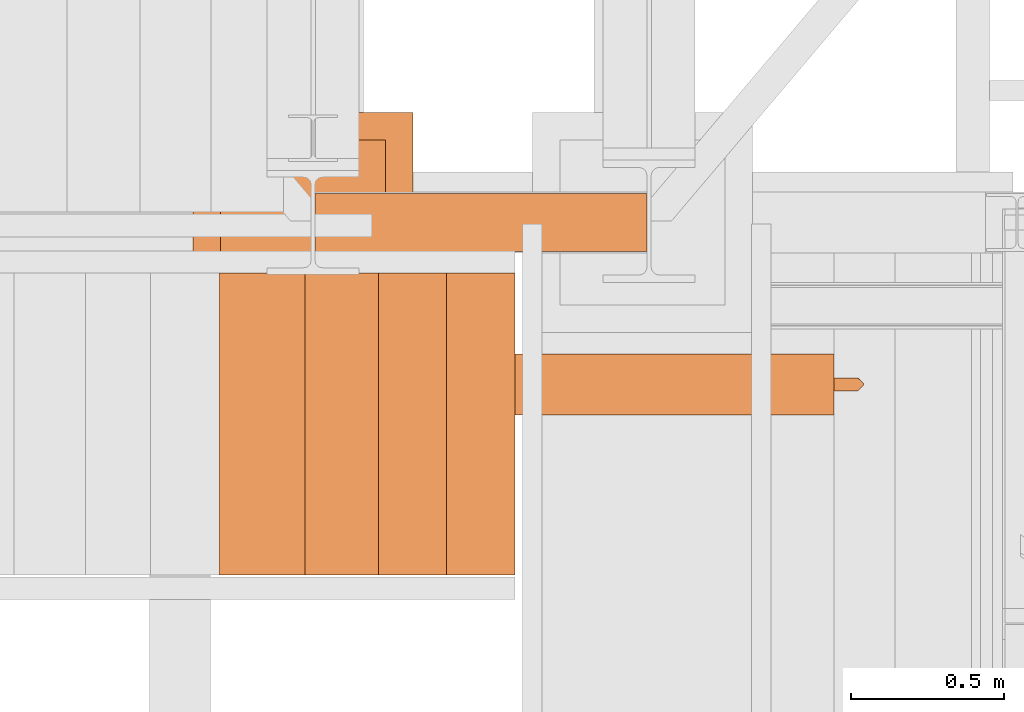
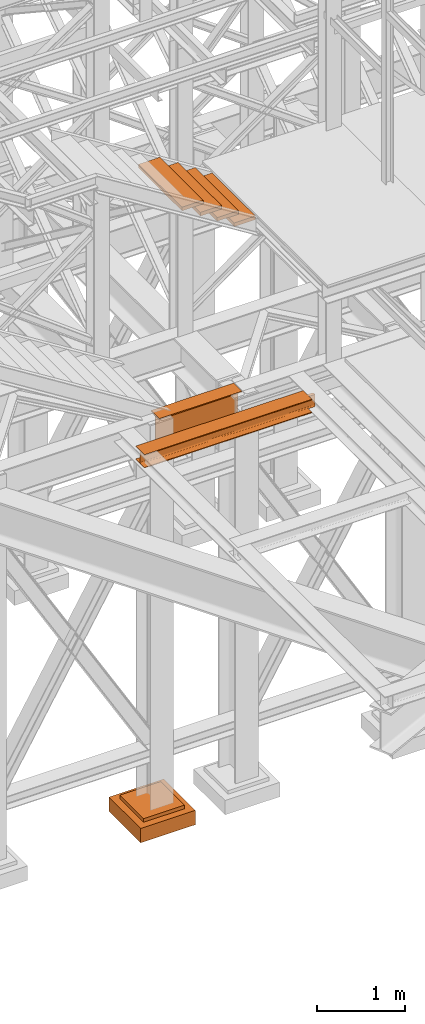
# One storey, part 23 of 208: 7 proxies.
"""IFC2X3 building model written with IfcOpenShell, lengths in millimetres."""

from ifc_helpers import new_model, entity, si_unit, converted_unit, frame, origin, origin_with_axes, place, context, subcontext, project, spatial, faceted_brep, element, save


model = new_model("IFC2X3")

# Units and contexts
model_context = context("Model", 3, precision=1e-05, world=origin())
plan_context = context("Plan", 3, precision=1e-05, world=origin())
body_context = subcontext(model_context, "Body", "Model", "MODEL_VIEW")
ifc_project = project(units=[si_unit("LENGTHUNIT", "METRE", prefix="MILLI"), converted_unit("PLANEANGLEUNIT", "DEGREE", entity("IfcPlaneAngleMeasure", 0.0174532925199433), si_unit("PLANEANGLEUNIT", "RADIAN"), dimensions=[0, 0, 0, 0, 0, 0, 0]), si_unit("AREAUNIT", "SQUARE_METRE"), si_unit("VOLUMEUNIT", "CUBIC_METRE")], contexts=[model_context, plan_context])

# Building, storey
building_placement = place(None, origin())
building = spatial("IfcBuilding", under=ifc_project, at=building_placement, CompositionType="COMPLEX")
storey_placement = place(building_placement, origin_with_axes())
storey = spatial("IfcBuildingStorey", under=building, at=storey_placement, Name="Geschoss", CompositionType="ELEMENT")

# Proxies
proxy_1_placement = place(storey_placement, frame((-1100.745031419179, -17357.574399786, 4834.989987483023), z_axis=(0.0, 0.0, 1.0), x_axis=(1.0, 0.0, 0.0)))
element("IfcBuildingElementProxy", 1, at=proxy_1_placement, inside=storey, context=body_context, shape_type="Brep", body=[
    faceted_brep([(1088.009999895696, 0.00999999999839929, 450.0100178813937), (1088.009999895696, 190.0100125169738, 450.0100178813937), (1088.009999895696, 190.0100125169738, 435.4100240564349), (1088.009999895696, 120.7100073045476, 435.4100091552737), (1088.009999895696, 109.8415622657522, 433.2347078418734), (1088.009999895696, 101.8853126263603, 425.2784563398363), (1088.009999895696, 99.71000619068582, 414.4100113010409), (1088.009999895696, 99.71000619068582, 35.60999167919181), (1088.009999895696, 101.8853126263603, 24.74154664039634), (1088.009999895696, 109.8415622657522, 16.78529513835929), (1088.009999895696, 120.7100073045476, 14.60999382495902), (1088.009999895696, 190.0100125169738, 14.60999382495902), (1088.009999895696, 190.0100125169738, 0.01000000000021828), (1088.009999895696, 0.00999999999839929, 0.01000000000021828), (1088.009999895696, 0.00999999999839929, 14.60999382495902), (1088.009999895696, 69.31000521242458, 14.60999382495902), (1088.009999895696, 80.17845025122006, 16.78529513835929), (1088.009999895696, 88.13469989061196, 24.74154664039634), (1088.009999895696, 90.31000632628638, 35.60999167919181), (1088.009999895696, 90.31000632628638, 414.4100113010409), (1088.009999895696, 88.13469989061196, 425.2784563398363), (1088.009999895696, 80.17845025122006, 433.2347078418734), (1088.009999895696, 69.31000521242458, 435.4100091552737), (1088.009999895696, 0.00999999999839929, 435.4100240564349), (1088.009999895696, 190.0100125169738, 450.0100178813937), (1088.009999895696, 0.00999999999839929, 450.0100178813937), (0.009999999999990905, 0.00999999999839929, 450.0100178813937), (0.009999999999990905, 190.0100125169738, 450.0100178813937), (1088.009999895696, 190.0100125169738, 435.4100240564349), (1088.009999895696, 190.0100125169738, 450.0100178813937), (0.009999999999990905, 190.0100125169738, 450.0100178813937), (0.009999999999990905, 190.0100125169738, 435.4100240564349), (1088.009999895696, 120.7100073045476, 435.4100091552737), (1088.009999895696, 190.0100125169738, 435.4100240564349), (0.009999999999990905, 190.0100125169738, 435.4100240564349), (0.009999999999990905, 120.7100073045476, 435.4100091552737), (1088.009999895696, 109.8415622657522, 433.2347078418734), (1088.009999895696, 120.7100073045476, 435.4100091552737), (0.009999999999990905, 120.7100073045476, 435.4100091552737), (0.009999999999990905, 109.8415622657522, 433.2347078418734), (1088.009999895696, 101.8853126263603, 425.2784563398363), (1088.009999895696, 109.8415622657522, 433.2347078418734), (0.009999999999990905, 109.8415622657522, 433.2347078418734), (0.009999999999990905, 101.8853126263603, 425.2784563398363), (1088.009999895696, 99.71000619068582, 414.4100113010409), (1088.009999895696, 101.8853126263603, 425.2784563398363), (0.009999999999990905, 101.8853126263603, 425.2784563398363), (0.009999999999990905, 99.71000619068582, 414.4100113010409), (1088.009999895696, 99.71000619068582, 35.60999167919181), (1088.009999895696, 99.71000619068582, 414.4100113010409), (0.009999999999990905, 99.71000619068582, 414.4100113010409), (0.009999999999990905, 99.71000619068582, 35.60999167919181), (1088.009999895696, 101.8853126263603, 24.74154664039634), (1088.009999895696, 99.71000619068582, 35.60999167919181), (0.009999999999990905, 99.71000619068582, 35.60999167919181), (0.009999999999990905, 101.8853126263603, 24.74154664039634), (1088.009999895696, 109.8415622657522, 16.78529513835929), (1088.009999895696, 101.8853126263603, 24.74154664039634), (0.009999999999990905, 101.8853126263603, 24.74154664039634), (0.009999999999990905, 109.8415622657522, 16.78529513835929), (1088.009999895696, 120.7100073045476, 14.60999382495902), (1088.009999895696, 109.8415622657522, 16.78529513835929), (0.009999999999990905, 109.8415622657522, 16.78529513835929), (0.009999999999990905, 120.7100073045476, 14.60999382495902), (1088.009999895696, 190.0100125169738, 14.60999382495902), (1088.009999895696, 120.7100073045476, 14.60999382495902), (0.009999999999990905, 120.7100073045476, 14.60999382495902), (0.009999999999990905, 190.0100125169738, 14.60999382495902), (1088.009999895696, 190.0100125169738, 0.01000000000021828), (1088.009999895696, 190.0100125169738, 14.60999382495902), (0.009999999999990905, 190.0100125169738, 14.60999382495902), (0.009999999999990905, 190.0100125169738, 0.01000000000021828), (1088.009999895696, 0.00999999999839929, 0.01000000000021828), (1088.009999895696, 190.0100125169738, 0.01000000000021828), (0.009999999999990905, 190.0100125169738, 0.01000000000021828), (0.009999999999990905, 0.00999999999839929, 0.01000000000021828), (1088.009999895696, 0.00999999999839929, 14.60999382495902), (1088.009999895696, 0.00999999999839929, 0.01000000000021828), (0.009999999999990905, 0.00999999999839929, 0.01000000000021828), (0.009999999999990905, 0.00999999999839929, 14.60999382495902), (1088.009999895696, 69.31000521242458, 14.60999382495902), (1088.009999895696, 0.00999999999839929, 14.60999382495902), (0.009999999999990905, 0.00999999999839929, 14.60999382495902), (0.009999999999990905, 69.31000521242458, 14.60999382495902), (1088.009999895696, 80.17845025122006, 16.78529513835929), (1088.009999895696, 69.31000521242458, 14.60999382495902), (0.009999999999990905, 69.31000521242458, 14.60999382495902), (0.009999999999990905, 80.17845025122006, 16.78529513835929), (1088.009999895696, 88.13469989061196, 24.74154664039634), (1088.009999895696, 80.17845025122006, 16.78529513835929), (0.009999999999990905, 80.17845025122006, 16.78529513835929), (0.009999999999990905, 88.13469989061196, 24.74154664039634), (1088.009999895696, 90.31000632628638, 35.60999167919181), (1088.009999895696, 88.13469989061196, 24.74154664039634), (0.009999999999990905, 88.13469989061196, 24.74154664039634), (0.009999999999990905, 90.31000632628638, 35.60999167919181), (1088.009999895696, 90.31000632628638, 414.4100113010409), (1088.009999895696, 90.31000632628638, 35.60999167919181), (0.009999999999990905, 90.31000632628638, 35.60999167919181), (0.009999999999990905, 90.31000632628638, 414.4100113010409), (1088.009999895696, 88.13469989061196, 425.2784563398363), (1088.009999895696, 90.31000632628638, 414.4100113010409), (0.009999999999990905, 90.31000632628638, 414.4100113010409), (0.009999999999990905, 88.13469989061196, 425.2784563398363), (1088.009999895696, 80.17845025122006, 433.2347078418734), (1088.009999895696, 88.13469989061196, 425.2784563398363), (0.009999999999990905, 88.13469989061196, 425.2784563398363), (0.009999999999990905, 80.17845025122006, 433.2347078418734), (1088.009999895696, 69.31000521242458, 435.4100091552737), (1088.009999895696, 80.17845025122006, 433.2347078418734), (0.009999999999990905, 80.17845025122006, 433.2347078418734), (0.009999999999990905, 69.31000521242458, 435.4100091552737), (1088.009999895696, 0.00999999999839929, 435.4100240564349), (1088.009999895696, 69.31000521242458, 435.4100091552737), (0.009999999999990905, 69.31000521242458, 435.4100091552737), (0.009999999999990905, 0.00999999999839929, 435.4100240564349), (1088.009999895696, 0.00999999999839929, 450.0100178813937), (1088.009999895696, 0.00999999999839929, 435.4100240564349), (0.009999999999990905, 0.00999999999839929, 435.4100240564349), (0.009999999999990905, 0.00999999999839929, 450.0100178813937), (0.009999999999990905, 0.00999999999839929, 450.0100178813937), (0.009999999999990905, 0.00999999999839929, 435.4100240564349), (0.009999999999990905, 69.31000521242458, 435.4100091552737), (0.009999999999990905, 80.17845025122006, 433.2347078418734), (0.009999999999990905, 88.13469989061196, 425.2784563398363), (0.009999999999990905, 90.31000632628638, 414.4100113010409), (0.009999999999990905, 90.31000632628638, 35.60999167919181), (0.009999999999990905, 88.13469989061196, 24.74154664039634), (0.009999999999990905, 80.17845025122006, 16.78529513835929), (0.009999999999990905, 69.31000521242458, 14.60999382495902), (0.009999999999990905, 0.00999999999839929, 14.60999382495902), (0.009999999999990905, 0.00999999999839929, 0.01000000000021828), (0.009999999999990905, 190.0100125169738, 0.01000000000021828), (0.009999999999990905, 190.0100125169738, 14.60999382495902), (0.009999999999990905, 120.7100073045476, 14.60999382495902), (0.009999999999990905, 109.8415622657522, 16.78529513835929), (0.009999999999990905, 101.8853126263603, 24.74154664039634), (0.009999999999990905, 99.71000619068582, 35.60999167919181), (0.009999999999990905, 99.71000619068582, 414.4100113010409), (0.009999999999990905, 101.8853126263603, 425.2784563398363), (0.009999999999990905, 109.8415622657522, 433.2347078418734), (0.009999999999990905, 120.7100073045476, 435.4100091552737), (0.009999999999990905, 190.0100125169738, 435.4100240564349), (0.009999999999990905, 190.0100125169738, 450.0100178813937)], [[[0, 1, 2, 3, 4, 5, 6, 7, 8, 9, 10, 11, 12, 13, 14, 15, 16, 17, 18, 19, 20, 21, 22, 23]], [[24, 25, 26, 27]], [[28, 29, 30, 31]], [[32, 33, 34, 35]], [[36, 37, 38, 39]], [[40, 41, 42, 43]], [[44, 45, 46, 47]], [[48, 49, 50, 51]], [[52, 53, 54, 55]], [[56, 57, 58, 59]], [[60, 61, 62, 63]], [[64, 65, 66, 67]], [[68, 69, 70, 71]], [[72, 73, 74, 75]], [[76, 77, 78, 79]], [[80, 81, 82, 83]], [[84, 85, 86, 87]], [[88, 89, 90, 91]], [[92, 93, 94, 95]], [[96, 97, 98, 99]], [[100, 101, 102, 103]], [[104, 105, 106, 107]], [[108, 109, 110, 111]], [[112, 113, 114, 115]], [[116, 117, 118, 119]], [[120, 121, 122, 123, 124, 125, 126, 127, 128, 129, 130, 131, 132, 133, 134, 135, 136, 137, 138, 139, 140, 141, 142, 143]]], orient=[[False], [False], [False], [False], [False], [False], [False], [False], [False], [False], [False], [False], [False], [False], [False], [False], [False], [False], [False], [False], [False], [False], [False], [False], [False], [False]]),
])
proxy_2_placement = place(storey_placement, frame((-1499.794506223427, -17622.57439531565, -315.0099999999999), z_axis=(0.0, 0.0, 1.0), x_axis=(1.0, 0.0, 0.0)))
element("IfcBuildingElementProxy", 2, at=proxy_2_placement, inside=storey, context=body_context, shape_type="Brep", body=[
    faceted_brep([(630.01, 630.0099999999984, 250.01), (630.01, 90.0099999999984, 250.01), (90.00999999999999, 90.0099999999984, 250.01), (90.00999999999999, 630.0099999999984, 250.01), (630.01, 630.0099999999984, 200.01), (630.01, 90.0099999999984, 200.01), (630.01, 90.0099999999984, 250.01), (630.01, 630.0099999999984, 250.01), (90.00999999999999, 630.0099999999984, 200.01), (630.01, 630.0099999999984, 200.01), (630.01, 630.0099999999984, 250.01), (90.00999999999999, 630.0099999999984, 250.01), (90.00999999999999, 90.0099999999984, 200.01), (90.00999999999999, 630.0099999999984, 200.01), (90.00999999999999, 630.0099999999984, 250.01), (90.00999999999999, 90.0099999999984, 250.01), (630.01, 90.0099999999984, 200.01), (90.00999999999999, 90.0099999999984, 200.01), (90.00999999999999, 90.0099999999984, 250.01), (630.01, 90.0099999999984, 250.01), (720.01, 0.00999999999839929, 0.009999999999990905), (720.01, 720.0099999999984, 0.009999999999990905), (0.009999999999990905, 720.0099999999984, 0.009999999999990905), (0.009999999999990905, 0.00999999999839929, 0.009999999999990905), (720.01, 720.0099999999984, 200.01), (720.01, 0.00999999999839929, 200.01), (0.009999999999990905, 0.00999999999839929, 200.01), (0.009999999999990905, 720.0099999999984, 200.01), (90.00999999999999, 90.0099999999984, 200.01), (630.01, 90.0099999999984, 200.01), (630.01, 630.0099999999984, 200.01), (90.00999999999999, 630.0099999999984, 200.01), (720.01, 720.0099999999984, 0.009999999999990905), (720.01, 0.00999999999839929, 0.009999999999990905), (720.01, 0.00999999999839929, 200.01), (720.01, 720.0099999999984, 200.01), (0.009999999999990905, 720.0099999999984, 0.009999999999990905), (720.01, 720.0099999999984, 0.009999999999990905), (720.01, 720.0099999999984, 200.01), (0.009999999999990905, 720.0099999999984, 200.01), (0.009999999999990905, 0.00999999999839929, 0.009999999999990905), (0.009999999999990905, 720.0099999999984, 0.009999999999990905), (0.009999999999990905, 720.0099999999984, 200.01), (0.009999999999990905, 0.00999999999839929, 200.01), (720.01, 0.00999999999839929, 0.009999999999990905), (0.009999999999990905, 0.00999999999839929, 0.009999999999990905), (0.009999999999990905, 0.00999999999839929, 200.01), (720.01, 0.00999999999839929, 200.01)], [[[0, 1, 2, 3]], [[4, 5, 6, 7]], [[8, 9, 10, 11]], [[12, 13, 14, 15]], [[16, 17, 18, 19]], [[20, 21, 22, 23]], [[24, 25, 26, 27], [28, 29, 30, 31]], [[32, 33, 34, 35]], [[36, 37, 38, 39]], [[40, 41, 42, 43]], [[44, 45, 46, 47]]], orient=[[False], [False], [False], [False], [False], [False], [False, False], [False], [False], [False], [False]]),
])
proxy_3_placement = place(storey_placement, frame((-1605.876075509834, -17892.50386180536, 5094.990005364416), z_axis=(0.0, 0.0, 1.0), x_axis=(1.0, 0.0, 0.0)))
element("IfcBuildingElementProxy", 3, at=proxy_3_placement, inside=storey, context=body_context, shape_type="Brep", body=[
    faceted_brep([(0.01000000000180989, 200.0099999999984, 0.01000000000021828), (2204.141044038497, 200.0099999999984, 0.01000000000021828), (2204.141044038497, 200.0099999999984, 10.01000000000022), (0.01000000000180989, 200.0099999999984, 10.01000000000022), (0.01000000000180989, 200.0099999999984, 10.01000000000022), (2204.141044038497, 200.0099999999984, 10.01000000000022), (2204.141044038497, 121.2599999999984, 10.01000000000022), (0.01000000000180989, 121.2599999999984, 10.01000000000022), (0.01000000000180989, 121.2599999999984, 10.01000000000022), (2204.141044038497, 121.2599999999984, 10.01000000000022), (2282.891044038497, 121.2599999999984, 10.01000000000022), (2288.453331069071, 115.6977129694242, 10.89104403849342), (0.01000000000180989, 115.6977129694242, 10.89104403849342), (0.01000000000180989, 115.6977129694242, 10.89104403849342), (2288.453331069071, 115.6977129694242, 10.89104403849342), (2293.471160749032, 110.6798832894638, 13.44771635773213), (0.01000000000180989, 110.6798832894638, 13.44771635773213), (0.01000000000180989, 110.6798832894638, 13.44771635773213), (2293.471160749032, 110.6798832894638, 13.44771635773213), (2297.453327680767, 106.6977163577321, 17.42988328946558), (0.01000000000180989, 106.6977163577321, 17.42988328946558), (0.01000000000180989, 106.6977163577321, 17.42988328946558), (2297.453327680767, 106.6977163577321, 17.42988328946558), (2300.010000000002, 104.1410440384934, 22.44771296942599), (0.01000000000180989, 104.1410440384934, 22.44771296942599), (0.01000000000180989, 104.1410440384934, 22.44771296942599), (2300.010000000002, 104.1410440384934, 22.44771296942599), (2300.891044038497, 103.2599999999984, 28.01000000000022), (0.01000000000362888, 103.2599999999984, 28.01000000000022), (0.01000000000362888, 103.2599999999984, 28.01000000000022), (2300.891044038497, 103.2599999999984, 28.01000000000022), (2300.891044038497, 103.2599999999984, 162.0100000000002), (0.01000000000180989, 103.2599999999984, 162.0100000000002), (0.01000000000180989, 103.2599999999984, 162.0100000000002), (2300.891044038497, 103.2599999999984, 162.0100000000002), (2300.010000000002, 104.1410440384934, 167.5722870305744), (0.01000000000180989, 104.1410440384934, 167.5722870305744), (0.01000000000180989, 104.1410440384934, 167.5722870305744), (2300.010000000002, 104.1410440384934, 167.5722870305744), (2297.453327680767, 106.6977163577321, 172.5901167105349), (0.009999999999990905, 106.6977163577321, 172.5901167105349), (0.009999999999990905, 106.6977163577321, 172.5901167105349), (2297.453327680767, 106.6977163577321, 172.5901167105349), (2293.471160749032, 110.6798832894638, 176.5722836422683), (0.01000000000180989, 110.6798832894638, 176.5722836422683), (0.01000000000180989, 110.6798832894638, 176.5722836422683), (2293.471160749032, 110.6798832894638, 176.5722836422683), (2288.453331069071, 115.6977129694242, 179.1289559615061), (0.009999999999990905, 115.6977129694242, 179.128955961507), (0.009999999999990905, 115.6977129694242, 179.128955961507), (2288.453331069071, 115.6977129694242, 179.1289559615061), (2282.891044038497, 120.0099999999984, 180.0100000000002), (2204.141044038497, 120.0099999999984, 180.0100000000002), (0.01000000000180989, 120.0099999999984, 180.0100000000002), (0.01000000000180989, 120.0099999999984, 180.0100000000002), (2204.141044038497, 120.0099999999984, 180.0100000000002), (2204.141044038497, 200.0099999999984, 180.0100000000002), (0.01000000000180989, 200.0099999999984, 180.0100000000002), (0.01000000000180989, 200.0099999999984, 180.0100000000002), (2204.141044038497, 200.0099999999984, 180.0100000000002), (2204.141044038497, 200.0099999999984, 190.0100000000002), (0.01000000000180989, 200.0099999999984, 190.0100000000002), (0.01000000000180989, 200.0099999999984, 190.0100000000002), (2204.141044038497, 200.0099999999984, 190.0100000000002), (2204.141044038497, 0.00999999999839929, 190.0100000000002), (0.01000000000180989, 0.00999999999839929, 190.0100000000002), (0.01000000000180989, 0.00999999999839929, 190.0100000000002), (2204.141044038497, 0.00999999999839929, 190.0100000000002), (2204.141044038497, 0.00999999999839929, 180.0100000000002), (0.01000000000180989, 0.00999999999839929, 180.0100000000002), (0.01000000000180989, 0.00999999999839929, 180.0100000000002), (2204.141044038497, 0.00999999999839929, 180.0100000000002), (2204.141044038497, 78.7599999999984, 180.0100000000002), (0.01000000000180989, 78.7599999999984, 180.0100000000002), (0.01000000000180989, 78.7599999999984, 180.0100000000002), (2204.141044038497, 78.7599999999984, 180.0100000000002), (2282.891044038497, 78.7599999999984, 180.0100000000002), (2288.453331069071, 84.32228703057262, 179.1289559615061), (0.009999999999990905, 84.32228703057262, 179.128955961507), (0.009999999999990905, 84.32228703057262, 179.128955961507), (2288.453331069071, 84.32228703057262, 179.1289559615061), (2293.471160749032, 89.34011671053304, 176.5722836422683), (0.01000000000180989, 89.34011671053304, 176.5722836422683), (0.01000000000180989, 89.34011671053304, 176.5722836422683), (2293.471160749032, 89.34011671053304, 176.5722836422683), (2297.453327680767, 93.3222836422683, 172.5901167105349), (0.01000000000180989, 93.3222836422683, 172.5901167105349), (0.01000000000180989, 93.3222836422683, 172.5901167105349), (2297.453327680767, 93.3222836422683, 172.5901167105349), (2300.010000000003, 95.87895596150338, 167.5722870305735), (0.01000000000180989, 95.87895596150338, 167.5722870305744), (0.01000000000180989, 95.87895596150338, 167.5722870305744), (2300.010000000003, 95.87895596150338, 167.5722870305735), (2300.891044038497, 96.7599999999984, 162.0100000000002), (0.01000000000180989, 96.7599999999984, 162.0100000000002), (0.01000000000180989, 96.7599999999984, 162.0100000000002), (2300.891044038497, 96.7599999999984, 162.0100000000002), (2300.891044038497, 96.7599999999984, 28.01000000000022), (0.01000000000180989, 96.7599999999984, 28.01000000000022), (0.01000000000180989, 96.7599999999984, 28.01000000000022), (2300.891044038497, 96.7599999999984, 28.01000000000022), (2300.010000000003, 95.87895596150338, 22.44771296942508), (0.01000000000180989, 95.87895596150338, 22.44771296942599), (0.01000000000180989, 95.87895596150338, 22.44771296942599), (2300.010000000003, 95.87895596150338, 22.44771296942508), (2297.453327680767, 93.3222836422683, 17.42988328946558), (0.01000000000180989, 93.3222836422683, 17.42988328946558), (0.01000000000180989, 93.3222836422683, 17.42988328946558), (2297.453327680767, 93.3222836422683, 17.42988328946558), (2293.471160749032, 89.34011671053304, 13.44771635773213), (0.009999999999990905, 89.34011671053304, 13.44771635773213), (0.009999999999990905, 89.34011671053304, 13.44771635773213), (2293.471160749032, 89.34011671053304, 13.44771635773213), (2288.453331069071, 84.32228703057262, 10.89104403849342), (0.01000000000180989, 84.32228703057262, 10.89104403849342), (0.01000000000180989, 84.32228703057262, 10.89104403849342), (2288.453331069071, 84.32228703057262, 10.89104403849342), (2282.891044038497, 78.7599999999984, 10.01000000000022), (2204.141044038497, 78.7599999999984, 10.01000000000022), (0.01000000000180989, 78.7599999999984, 10.01000000000022), (0.01000000000180989, 78.7599999999984, 10.01000000000022), (2204.141044038497, 78.7599999999984, 10.01000000000022), (2204.141044038497, 0.00999999999839929, 10.01000000000022), (0.01000000000180989, 0.00999999999839929, 10.01000000000022), (0.01000000000180989, 0.00999999999839929, 10.01000000000022), (2204.141044038497, 0.00999999999839929, 10.01000000000022), (2204.141044038497, 0.00999999999839929, 0.01000000000021828), (0.01000000000180989, 0.00999999999839929, 0.01000000000021828), (0.01000000000180989, 0.00999999999839929, 0.01000000000021828), (2204.141044038497, 0.00999999999839929, 0.01000000000021828), (2204.141044038497, 200.0099999999984, 0.01000000000021828), (0.01000000000180989, 200.0099999999984, 0.01000000000021828), (2300.891044038497, 96.7599999999984, 28.01000000000022), (2300.891044038497, 96.7599999999984, 162.0100000000002), (2300.891044038497, 103.2599999999984, 162.0100000000002), (2300.891044038497, 103.2599999999984, 28.01000000000022), (2204.141044038497, 200.0099999999984, 190.0100000000002), (2204.141044038497, 200.0099999999984, 180.0100000000002), (2204.141044038497, 120.0099999999984, 180.0100000000002), (2204.141044038497, 78.7599999999984, 180.0100000000002), (2204.141044038497, 0.00999999999839929, 180.0100000000002), (2204.141044038497, 0.00999999999839929, 190.0100000000002), (2204.141044038497, 120.0099999999984, 180.0100000000002), (2282.891044038497, 120.0099999999984, 180.0100000000002), (2282.891044038497, 78.7599999999984, 180.0100000000002), (2204.141044038497, 78.7599999999984, 180.0100000000002), (2282.891044038497, 120.0099999999984, 180.0100000000002), (2288.453331069071, 115.6977129694242, 179.1289559615061), (2288.453331069071, 84.32228703057262, 179.1289559615061), (2282.891044038497, 78.7599999999984, 180.0100000000002), (2288.453331069071, 115.6977129694242, 179.1289559615061), (2293.471160749032, 110.6798832894638, 176.5722836422683), (2293.471160749032, 89.34011671053304, 176.5722836422683), (2288.453331069071, 84.32228703057262, 179.1289559615061), (2293.471160749032, 110.6798832894638, 176.5722836422683), (2297.453327680767, 106.6977163577321, 172.5901167105349), (2297.453327680767, 93.3222836422683, 172.5901167105349), (2293.471160749032, 89.34011671053304, 176.5722836422683), (2297.453327680767, 106.6977163577321, 172.5901167105349), (2300.010000000002, 104.1410440384934, 167.5722870305744), (2300.010000000003, 95.87895596150338, 167.5722870305735), (2297.453327680767, 93.3222836422683, 172.5901167105349), (2300.010000000002, 104.1410440384934, 167.5722870305744), (2300.891044038497, 103.2599999999984, 162.0100000000002), (2300.891044038497, 96.7599999999984, 162.0100000000002), (2300.010000000003, 95.87895596150338, 167.5722870305735), (2300.891044038497, 103.2599999999984, 28.01000000000022), (2300.010000000002, 104.1410440384934, 22.44771296942599), (2300.010000000003, 95.87895596150338, 22.44771296942508), (2300.891044038497, 96.7599999999984, 28.01000000000022), (2300.010000000002, 104.1410440384934, 22.44771296942599), (2297.453327680767, 106.6977163577321, 17.42988328946558), (2297.453327680767, 93.3222836422683, 17.42988328946558), (2300.010000000003, 95.87895596150338, 22.44771296942508), (2297.453327680767, 106.6977163577321, 17.42988328946558), (2293.471160749032, 110.6798832894638, 13.44771635773213), (2293.471160749032, 89.34011671053304, 13.44771635773213), (2297.453327680767, 93.3222836422683, 17.42988328946558), (2293.471160749032, 110.6798832894638, 13.44771635773213), (2288.453331069071, 115.6977129694242, 10.89104403849342), (2288.453331069071, 84.32228703057262, 10.89104403849342), (2293.471160749032, 89.34011671053304, 13.44771635773213), (2288.453331069071, 115.6977129694242, 10.89104403849342), (2282.891044038497, 121.2599999999984, 10.01000000000022), (2282.891044038497, 78.7599999999984, 10.01000000000022), (2288.453331069071, 84.32228703057262, 10.89104403849342), (2282.891044038497, 121.2599999999984, 10.01000000000022), (2204.141044038497, 121.2599999999984, 10.01000000000022), (2204.141044038497, 78.7599999999984, 10.01000000000022), (2282.891044038497, 78.7599999999984, 10.01000000000022), (2204.141044038497, 200.0099999999984, 10.01000000000022), (2204.141044038497, 200.0099999999984, 0.01000000000021828), (2204.141044038497, 0.00999999999839929, 0.01000000000021828), (2204.141044038497, 0.00999999999839929, 10.01000000000022), (2204.141044038497, 78.7599999999984, 10.01000000000022), (2204.141044038497, 121.2599999999984, 10.01000000000022), (0.01000000000180989, 200.0099999999984, 10.01000000000022), (0.01000000000180989, 121.2599999999984, 10.01000000000022), (0.01000000000180989, 115.6977129694242, 10.89104403849342), (0.01000000000180989, 110.6798832894638, 13.44771635773213), (0.01000000000180989, 106.6977163577321, 17.42988328946558), (0.01000000000180989, 104.1410440384934, 22.44771296942599), (0.01000000000362888, 103.2599999999984, 28.01000000000022), (0.01000000000180989, 103.2599999999984, 162.0100000000002), (0.01000000000180989, 104.1410440384934, 167.5722870305744), (0.009999999999990905, 106.6977163577321, 172.5901167105349), (0.01000000000180989, 110.6798832894638, 176.5722836422683), (0.009999999999990905, 115.6977129694242, 179.128955961507), (0.01000000000180989, 120.0099999999984, 180.0100000000002), (0.01000000000180989, 200.0099999999984, 180.0100000000002), (0.01000000000180989, 200.0099999999984, 190.0100000000002), (0.01000000000180989, 0.00999999999839929, 190.0100000000002), (0.01000000000180989, 0.00999999999839929, 180.0100000000002), (0.01000000000180989, 78.7599999999984, 180.0100000000002), (0.009999999999990905, 84.32228703057262, 179.128955961507), (0.01000000000180989, 89.34011671053304, 176.5722836422683), (0.01000000000180989, 93.3222836422683, 172.5901167105349), (0.01000000000180989, 95.87895596150338, 167.5722870305744), (0.01000000000180989, 96.7599999999984, 162.0100000000002), (0.01000000000180989, 96.7599999999984, 28.01000000000022), (0.01000000000180989, 95.87895596150338, 22.44771296942599), (0.01000000000180989, 93.3222836422683, 17.42988328946558), (0.009999999999990905, 89.34011671053304, 13.44771635773213), (0.01000000000180989, 84.32228703057262, 10.89104403849342), (0.01000000000180989, 78.7599999999984, 10.01000000000022), (0.01000000000180989, 0.00999999999839929, 10.01000000000022), (0.01000000000180989, 0.00999999999839929, 0.01000000000021828), (0.01000000000180989, 200.0099999999984, 0.01000000000021828)], [[[0, 1, 2, 3]], [[4, 5, 6, 7]], [[8, 9, 10, 11, 12]], [[13, 14, 15, 16]], [[17, 18, 19, 20]], [[21, 22, 23, 24]], [[25, 26, 27, 28]], [[29, 30, 31, 32]], [[33, 34, 35, 36]], [[37, 38, 39, 40]], [[41, 42, 43, 44]], [[45, 46, 47, 48]], [[49, 50, 51, 52, 53]], [[54, 55, 56, 57]], [[58, 59, 60, 61]], [[62, 63, 64, 65]], [[66, 67, 68, 69]], [[70, 71, 72, 73]], [[74, 75, 76, 77, 78]], [[79, 80, 81, 82]], [[83, 84, 85, 86]], [[87, 88, 89, 90]], [[91, 92, 93, 94]], [[95, 96, 97, 98]], [[99, 100, 101, 102]], [[103, 104, 105, 106]], [[107, 108, 109, 110]], [[111, 112, 113, 114]], [[115, 116, 117, 118, 119]], [[120, 121, 122, 123]], [[124, 125, 126, 127]], [[128, 129, 130, 131]], [[132, 133, 134, 135]], [[136, 137, 138, 139, 140, 141]], [[142, 143, 144, 145]], [[146, 147, 148, 149]], [[150, 151, 152, 153]], [[154, 155, 156, 157]], [[158, 159, 160, 161]], [[162, 163, 164, 165]], [[166, 167, 168, 169]], [[170, 171, 172, 173]], [[174, 175, 176, 177]], [[178, 179, 180, 181]], [[182, 183, 184, 185]], [[186, 187, 188, 189]], [[190, 191, 192, 193, 194, 195]], [[196, 197, 198, 199, 200, 201, 202, 203, 204, 205, 206, 207, 208, 209, 210, 211, 212, 213, 214, 215, 216, 217, 218, 219, 220, 221, 222, 223, 224, 225, 226, 227]]], orient=[[False], [False], [False], [False], [False], [False], [False], [False], [False], [False], [False], [False], [False], [False], [False], [False], [False], [False], [False], [False], [False], [False], [False], [False], [False], [False], [False], [False], [False], [False], [False], [False], [False], [False], [False], [False], [False], [False], [False], [False], [False], [False], [False], [False], [False], [False], [False], [False]]),
])
for number, where, z_axis, x_axis in (
    (4, (-726.3988952621855, -18416.66561009758, 8467.684418044078), (0.0, 0.0, 1.0), (1.0, 0.0, 0.0)),
    (5, (-949.83407610466, -18416.66561009758, 8620.811140297237), (0.0, 0.0, 1.0), (1.0, 0.0, 0.0)),
    (6, (-1173.240784282465, -18416.66561009758, 8769.681651260578), (0.0, 0.0, 1.0), (1.0, 0.0, 0.0)),
    (7, (-1414.09405321244, -18416.66561009758, 8927.020714616772), (0.0, 0.0, 1.0), (1.0, 0.0, 0.0)),
):
    element("IfcBuildingElementProxy", number, at=place(storey_placement, frame(where, z_axis=z_axis, x_axis=x_axis)), inside=storey, context=body_context, shape_type="Brep", body=[
        faceted_brep([(0.009999999999990905, 0.00999999999839929, 0.01000000000021828), (280.2746556316176, 0.00999999999839929, 0.01000000000021828), (280.2746556316176, 988.9080206708568, 0.01000000000021828), (0.009999999999990905, 988.9080206708568, 0.01000000000021828), (280.2746556316176, 0.00999999999839929, 50.01000000000022), (0.009999999999990905, 0.00999999999839929, 50.01000000000022), (0.009999999999990905, 988.9080206708568, 50.01000000000022), (280.2746556316176, 988.9080206708568, 50.01000000000022), (280.2746556316176, 0.00999999999839929, 0.01000000000021828), (0.009999999999990905, 0.00999999999839929, 0.01000000000021828), (0.009999999999990905, 0.00999999999839929, 50.01000000000022), (280.2746556316176, 0.00999999999839929, 50.01000000000022), (280.2746556316176, 988.9080206708568, 0.01000000000021828), (280.2746556316176, 0.00999999999839929, 0.01000000000021828), (280.2746556316176, 0.00999999999839929, 50.01000000000022), (280.2746556316176, 988.9080206708568, 50.01000000000022), (0.009999999999990905, 988.9080206708568, 0.01000000000021828), (280.2746556316176, 988.9080206708568, 0.01000000000021828), (280.2746556316176, 988.9080206708568, 50.01000000000022), (0.009999999999990905, 988.9080206708568, 50.01000000000022), (0.009999999999990905, 0.00999999999839929, 0.01000000000021828), (0.009999999999990905, 988.9080206708568, 0.01000000000021828), (0.009999999999990905, 988.9080206708568, 50.01000000000022), (0.009999999999990905, 0.00999999999839929, 50.01000000000022)], [[[0, 1, 2, 3]], [[4, 5, 6, 7]], [[8, 9, 10, 11]], [[12, 13, 14, 15]], [[16, 17, 18, 19]], [[20, 21, 22, 23]]], orient=[[False], [False], [False], [False], [False], [False]]),
    ])

save(model, "model.ifc")
